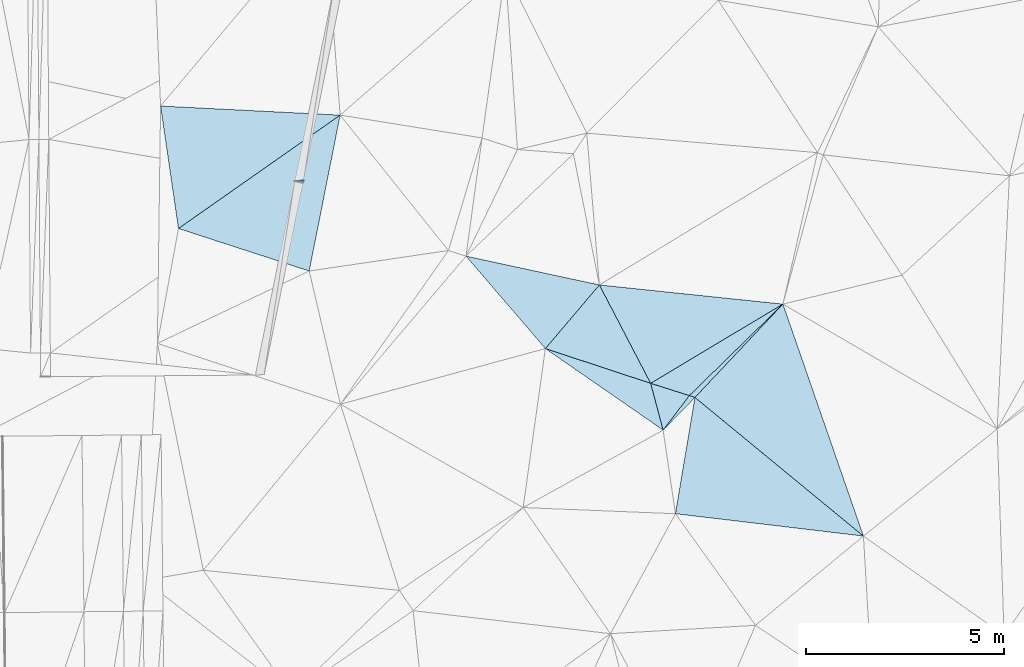
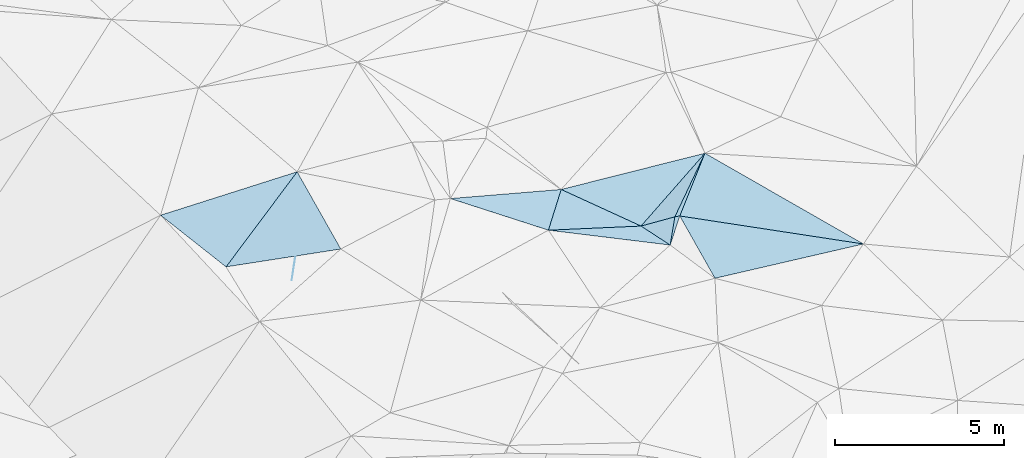
# One storey, part 40 of 275: 13 plates.
"""IFC2X3 building model written with IfcOpenShell, lengths in millimetres."""

from ifc_helpers import new_model, si_unit, frame, origin_with_axes, place, context, subcontext, project, spatial, polyline, outline, extrude, material, type_object, element, save


model = new_model("IFC2X3")

# Units and contexts
model_context = context("Model", 3, precision=1e-05, world=origin_with_axes())
body_context = subcontext(model_context, "Body", "Model", "MODEL_VIEW")
ifc_project = project(units=[si_unit("LENGTHUNIT", "METRE", prefix="MILLI"), si_unit("AREAUNIT", "SQUARE_METRE"), si_unit("VOLUMEUNIT", "CUBIC_METRE"), si_unit("MASSUNIT", "GRAM", prefix="KILO"), si_unit("TIMEUNIT", "SECOND"), si_unit("PLANEANGLEUNIT", "RADIAN"), si_unit("SOLIDANGLEUNIT", "STERADIAN"), si_unit("THERMODYNAMICTEMPERATUREUNIT", "DEGREE_CELSIUS"), si_unit("LUMINOUSINTENSITYUNIT", "LUMEN")], contexts=[model_context])

# Site, building, storey
site_placement = place(None, origin_with_axes())
site = spatial("IfcSite", under=ifc_project, at=site_placement, CompositionType="ELEMENT")
building_placement = place(site_placement, origin_with_axes())
building = spatial("IfcBuilding", under=site, at=building_placement, Name="Undefined", CompositionType="ELEMENT")
storey_placement = place(building_placement, origin_with_axes())
storey = spatial("IfcBuildingStorey", under=building, at=storey_placement, Name="Undefined", CompositionType="ELEMENT", Elevation=0.0)

# Plates
ifc_material = material()
plate_type_1 = type_object("IfcPlateType", PredefinedType="NOTDEFINED")
plate_1_placement = place(storey_placement, frame((-48201.0291427002, 28704.6195683851, 43408.5790019681), z_axis=(0.944391877323422, -0.297531897439211, -0.139995542971074), x_axis=(-0.303201074828322, -0.9527044124579, -0.0205769459880999)))
element("IfcPlate", 1, at=plate_1_placement, inside=storey, type_object=plate_type_1, material=ifc_material, Name="00_PR", context=body_context, shape_type="SweptSolid", body=[
    extrude(outline(polyline([(0.0, 0.0), (45.9737815856934, -7.27595761418343e-11), (109.312965393066, 1514.12231445313), (0.0, 0.0)])), frame((-8.85201319254618e-08, 2.18876761149539e-07, -0.5000001331573), z_axis=(0.0, 0.0, 1.0), x_axis=(1.0, 0.0, 0.0)), (0.0, 0.0, 1.0), 1.0),
])
plate_type_2 = type_object("IfcPlateType", PredefinedType="NOTDEFINED")
plate_2_placement = place(storey_placement, frame((-36076.8352869013, 25587.5278912254, 44069.5011480383), z_axis=(0.0602645456918242, -0.031438902161707, -0.997687215495631), x_axis=(-0.685691146536518, -0.727657758447014, -0.0184888651166518)))
element("IfcPlate", 2, at=plate_2_placement, inside=storey, type_object=plate_type_2, material=ifc_material, Name="00", context=body_context, shape_type="SweptSolid", body=[
    extrude(outline(polyline([(0.0, 0.0), (3245.19653320313, -1.45519152283669e-09), (3307.90454101563, 135.158050537109), (0.0, 0.0)])), frame((-8.85201319254618e-08, 2.18876761149539e-07, -0.5000001331573), z_axis=(0.0, 0.0, 1.0), x_axis=(1.0, 0.0, 0.0)), (0.0, 0.0, 1.0), 1.0),
])
plate_type_3 = type_object("IfcPlateType", PredefinedType="NOTDEFINED")
plate_3_placement = place(storey_placement, frame((-38302.0701801519, 23226.2023642156, 44009.5026174157), z_axis=(-0.00457012216473451, 0.102254218591217, -0.994747801587769), x_axis=(0.770403316488194, -0.633845193562741, -0.0686949819230087)))
element("IfcPlate", 3, at=plate_3_placement, inside=storey, type_object=plate_type_3, material=ifc_material, Name="00", context=body_context, shape_type="SweptSolid", body=[
    extrude(outline(polyline([(0.0, 0.0), (5531.69970703125, 5.34419086761773e-09), (1504.51049804688, 2591.55322265625), (0.0, 0.0)])), frame((-8.85201319254618e-08, 2.18876761149539e-07, -0.5000001331573), z_axis=(0.0, 0.0, 1.0), x_axis=(1.0, 0.0, 0.0)), (0.0, 0.0, 1.0), 1.0),
])
plate_type_4 = type_object("IfcPlateType", PredefinedType="NOTDEFINED")
plate_4_placement = place(storey_placement, frame((-39422.2016416948, 23583.784123186, 43819.5158297411), z_axis=(0.217119168869726, 0.123331350886721, -0.968322593146404), x_axis=(0.938895708832874, -0.297804000295462, 0.172590919063653)))
element("IfcPlate", 4, at=plate_4_placement, inside=storey, type_object=plate_type_4, material=ifc_material, Name="00", context=body_context, shape_type="SweptSolid", body=[
    extrude(outline(polyline([(0.0, 0.0), (1042.92858886719, -1.32058630697429e-09), (634.846923828125, 1050.50915527344), (0.0, 0.0)])), frame((-8.85201319254618e-08, 2.18876761149539e-07, -0.5000001331573), z_axis=(0.0, 0.0, 1.0), x_axis=(1.0, 0.0, 0.0)), (0.0, 0.0, 1.0), 1.0),
])
plate_type_5 = type_object("IfcPlateType", PredefinedType="NOTDEFINED")
plate_5_placement = place(storey_placement, frame((-38443.0430065557, 23273.2288498206, 43999.5135011573), z_axis=(0.132072296504589, 0.189384266317632, -0.972980219823269), x_axis=(0.946606199340395, -0.315328715444219, 0.0671156061332304)))
element("IfcPlate", 5, at=plate_5_placement, inside=storey, type_object=plate_type_5, material=ifc_material, Name="00", context=body_context, shape_type="SweptSolid", body=[
    extrude(outline(polyline([(0.0, 0.0), (148.996643066406, -4.40195435658097e-10), (-370.478149414063, 1064.35241699219), (0.0, 0.0)])), frame((-8.85201319254618e-08, 2.18876761149539e-07, -0.5000001331573), z_axis=(0.0, 0.0, 1.0), x_axis=(1.0, 0.0, 0.0)), (0.0, 0.0, 1.0), 1.0),
])
plate_type_6 = type_object("IfcPlateType", PredefinedType="NOTDEFINED")
plate_6_placement = place(storey_placement, frame((-36076.7937028906, 25587.4850980689, 44069.5086451961), z_axis=(0.143527019330944, -0.117019327669123, -0.982703654045227), x_axis=(-0.714733722741236, -0.69907699552464, -0.0211437911618457)))
element("IfcPlate", 6, at=plate_6_placement, inside=storey, type_object=plate_type_6, material=ifc_material, Name="00", context=body_context, shape_type="SweptSolid", body=[
    extrude(outline(polyline([(0.0, 0.0), (3310.66455078125, 2.61934474110603e-09), (3797.21337890625, 922.48046875), (0.0, 0.0)])), frame((-8.85201319254618e-08, 2.18876761149539e-07, -0.5000001331573), z_axis=(0.0, 0.0, 1.0), x_axis=(1.0, 0.0, 0.0)), (0.0, 0.0, 1.0), 1.0),
])
plate_type_7 = type_object("IfcPlateType", PredefinedType="NOTDEFINED")
plate_7_placement = place(storey_placement, frame((-51365.2560939195, 27499.0256171075, 44149.5008874126), z_axis=(0.0292417473632478, 0.0522704131117647, -0.998204750601934), x_axis=(-0.144352452602623, 0.988384292610965, 0.0475274609834054)))
element("IfcPlate", 7, at=plate_7_placement, inside=storey, type_object=plate_type_7, material=ifc_material, Name="00", context=body_context, shape_type="SweptSolid", body=[
    extrude(outline(polyline([(0.0, 0.0), (3135.02978515625, -3.46335582435131e-09), (2257.65649414063, 4463.94287109375), (0.0, 0.0)])), frame((-8.85201319254618e-08, 2.18876761149539e-07, -0.5000001331573), z_axis=(0.0, 0.0, 1.0), x_axis=(1.0, 0.0, 0.0)), (0.0, 0.0, 1.0), 1.0),
])
plate_type_8 = type_object("IfcPlateType", PredefinedType="NOTDEFINED")
plate_8_placement = place(storey_placement, frame((-42084.8981399374, 24462.1724768707, 44069.5020630143), z_axis=(-0.0781718613235673, 0.0464780606908002, -0.995855888154321), x_axis=(0.945898496237928, -0.312070356398317, -0.0888151308744953)))
element("IfcPlate", 8, at=plate_8_placement, inside=storey, type_object=plate_type_8, material=ifc_material, Name="00", context=body_context, shape_type="SweptSolid", body=[
    extrude(outline(polyline([(0.0, 0.0), (2814.83569335938, -5.91899151913822e-09), (3489.6884765625, 1025.267578125), (0.0, 0.0)])), frame((-8.85201319254618e-08, 2.18876761149539e-07, -0.5000001331573), z_axis=(0.0, 0.0, 1.0), x_axis=(1.0, 0.0, 0.0)), (0.0, 0.0, 1.0), 1.0),
])
plate_type_9 = type_object("IfcPlateType", PredefinedType="NOTDEFINED")
plate_9_placement = place(storey_placement, frame((-40719.136462896, 26071.8764524492, 44089.5024972331), z_axis=(-0.0698056032244037, 0.0715896818905193, -0.994988489986337), x_axis=(0.460060511334349, -0.882705551223772, -0.0957874508978852)))
element("IfcPlate", 9, at=plate_9_placement, inside=storey, type_object=plate_type_9, material=ifc_material, Name="00", context=body_context, shape_type="SweptSolid", body=[
    extrude(outline(polyline([(0.0, 0.0), (2818.74096679688, 4.27462509833276e-09), (794.468200683594, 1955.91931152344), (0.0, 0.0)])), frame((-8.85201319254618e-08, 2.18876761149539e-07, -0.5000001331573), z_axis=(0.0, 0.0, 1.0), x_axis=(1.0, 0.0, 0.0)), (0.0, 0.0, 1.0), 1.0),
])
plate_type_10 = type_object("IfcPlateType", PredefinedType="NOTDEFINED")
plate_10_placement = place(storey_placement, frame((-42084.9088040817, 24462.1976007611, 44069.5048285795), z_axis=(-0.099498546625446, 0.0967249937153472, -0.99032535805673), x_axis=(-0.645031101847935, 0.751553491980927, 0.138210803991996)))
element("IfcPlate", 10, at=plate_10_placement, inside=storey, type_object=plate_type_10, material=ifc_material, Name="00", context=body_context, shape_type="SweptSolid", body=[
    extrude(outline(polyline([(0.0, 0.0), (3111.189453125, 7.77436071075499e-09), (331.577362060547, 2084.91162109375), (0.0, 0.0)])), frame((-8.85201319254618e-08, 2.18876761149539e-07, -0.5000001331573), z_axis=(0.0, 0.0, 1.0), x_axis=(1.0, 0.0, 0.0)), (0.0, 0.0, 1.0), 1.0),
])
plate_type_11 = type_object("IfcPlateType", PredefinedType="NOTDEFINED")
plate_11_placement = place(storey_placement, frame((-47275.8840414108, 30367.4635701825, 44419.5007427711), z_axis=(0.0497608066398278, 0.0230451005555464, -0.998495260611155), x_axis=(-0.194539336445592, -0.980362055553582, -0.0323216120585594)))
element("IfcPlate", 11, at=plate_11_placement, inside=storey, type_object=plate_type_11, material=ifc_material, Name="00", context=body_context, shape_type="SweptSolid", body=[
    extrude(outline(polyline([(0.0, 0.0), (4022.07666015625, 3.7325662560761e-09), (3616.390625, 3456.22900390625), (0.0, 0.0)])), frame((-8.85201319254618e-08, 2.18876761149539e-07, -0.5000001331573), z_axis=(0.0, 0.0, 1.0), x_axis=(1.0, 0.0, 0.0)), (0.0, 0.0, 1.0), 1.0),
])
plate_type_12 = type_object("IfcPlateType", PredefinedType="NOTDEFINED")
plate_12_placement = place(storey_placement, frame((-39422.3065157679, 23583.778294431, 43819.5031325196), z_axis=(0.00736916504534815, 0.111674755790216, -0.993717487179193), x_axis=(-0.460060511326905, 0.882705551225531, 0.0957874509174249)))
element("IfcPlate", 12, at=plate_12_placement, inside=storey, type_object=plate_type_12, material=ifc_material, Name="00", context=body_context, shape_type="SweptSolid", body=[
    extrude(outline(polyline([(0.0, 0.0), (2818.74096679688, 4.27462509833276e-09), (253.623886108398, 3899.419921875), (0.0, 0.0)])), frame((-8.85201319254618e-08, 2.18876761149539e-07, -0.5000001331573), z_axis=(0.0, 0.0, 1.0), x_axis=(1.0, 0.0, 0.0)), (0.0, 0.0, 1.0), 1.0),
])
plate_type_13 = type_object("IfcPlateType", PredefinedType="NOTDEFINED")
plate_13_placement = place(storey_placement, frame((-34040.4473862916, 19719.9407990943, 43629.5013059012), z_axis=(-0.0383503846165189, 0.0614805259932558, -0.997371241275463), x_axis=(-0.770403316488348, 0.633845193561933, 0.0686949819287317)))
element("IfcPlate", 13, at=plate_13_placement, inside=storey, type_object=plate_type_13, material=ifc_material, Name="00", context=body_context, shape_type="SweptSolid", body=[
    extrude(outline(polyline([(0.0, 0.0), (5531.69970703125, 5.34419086761773e-09), (5318.27490234375, 3238.1708984375), (0.0, 0.0)])), frame((-8.85201319254618e-08, 2.18876761149539e-07, -0.5000001331573), z_axis=(0.0, 0.0, 1.0), x_axis=(1.0, 0.0, 0.0)), (0.0, 0.0, 1.0), 1.0),
])

save(model, "model.ifc")
